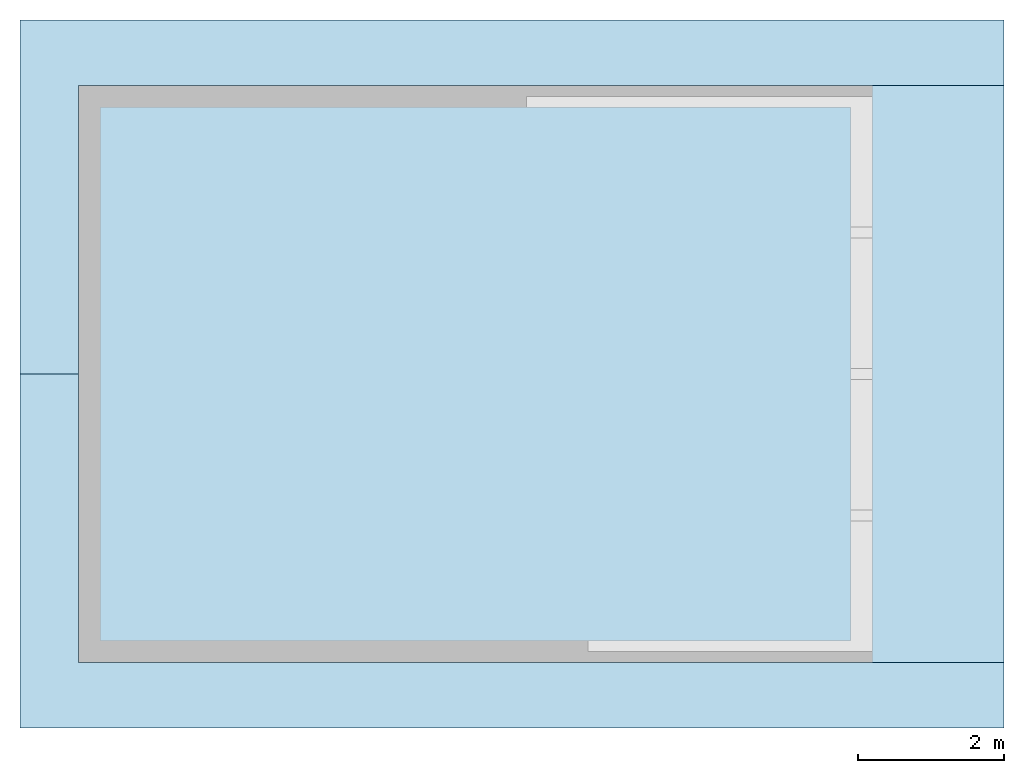
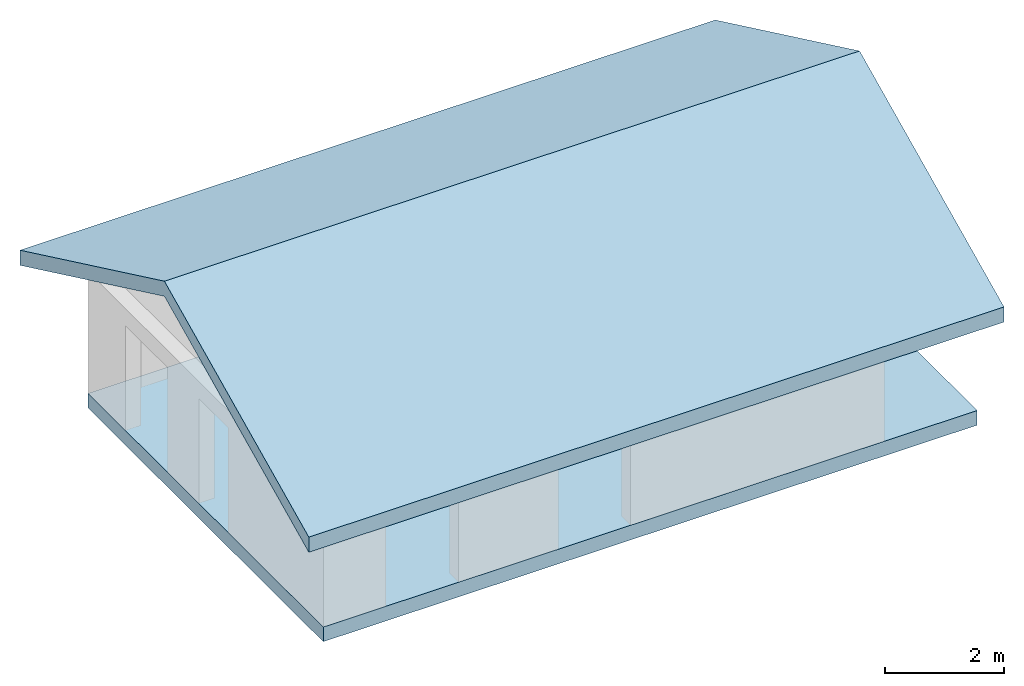
# Not in any storey, part 1 of 2: 2 slabs.
"""IFC4 model written with IfcOpenShell, lengths in metres."""

from ifc_helpers import new_model, entity, si_unit, converted_unit, frame, frame_2d, origin_with_axes, place, context, subcontext, project, polygons, material, element, save


model = new_model("IFC4")

# Units and contexts
model_context = context("Model", 3, precision=1e-05, world=origin_with_axes())
plan_context = context("Plan", 2, precision=1e-05, world=frame_2d((0.0, 0.0, 0.0), x_axis=(1.0, 0.0, 0.0)))
body_context = subcontext(model_context, "Body", "Model", "MODEL_VIEW")
ifc_project = project(units=[converted_unit("PLANEANGLEUNIT", "degree", entity("IfcReal", 0.0174532925199433), si_unit("PLANEANGLEUNIT", "RADIAN"), dimensions=[0, 0, 0, 0, 0, 0, 0]), si_unit("AREAUNIT", "SQUARE_METRE"), si_unit("VOLUMEUNIT", "CUBIC_METRE"), si_unit("LENGTHUNIT", "METRE")], contexts=[model_context, plan_context])

# Slabs
ifc_material = material(Name="concrete")
slab_1_placement = place(None, origin_with_axes())
element("IfcSlab", 1, at=slab_1_placement, material=ifc_material, PredefinedType="BASESLAB", context=body_context, shape_type="Tessellation", body=[
    polygons([(5.6100001335144, -0.400000005960464, 0.300000011920929), (4.21000003814697, -0.100000001490116, 0.300000011920929), (4.21000003814697, -0.400000005960464, 0.300000011920929), (5.6100001335144, -0.100000001490116, 0.300000011920929), (10.5299997329712, 7.5, 0.0), (10.5299997329712, -0.400000005960464, 0.300000011920929), (10.5299997329712, -0.400000005960464, 0.0), (10.5299997329712, 3.25999999046326, 0.300000011920929), (10.5299997329712, 7.19999980926514, 0.300000011920929), (10.5299997329712, 7.5, 0.300000011920929), (-0.349999994039536, 7.5, 0.300000011920929), (-0.349999994039536, 7.5, 0.0), (5.69000005722046, 7.5, 0.300000011920929), (10.2299995422363, 7.5, 0.300000011920929), (-0.349999994039536, 2.79999995231628, 0.300000011920929), (-0.349999994039536, -0.400000005960464, 0.0), (-0.349999994039536, -0.400000005960464, 0.300000011920929), (-0.349999994039536, 3.88000011444092, 0.300000011920929), (-0.349999994039536, 4.82895946502686, 0.300000011920929), (-0.349999994039536, 6.52895927429199, 0.300000011920929), (2.26999998092651, -0.400000005960464, 0.300000011920929), (0.870000004768372, -0.400000005960464, 0.300000011920929), (12.3299999237061, 7.5, 0.0), (12.3299999237061, -0.400000005960464, 0.300000011920929), (12.3299999237061, -0.400000005960464, 0.0), (12.3299999237061, 7.5, 0.300000011920929), (0.870000004768372, -0.100000001490116, 0.300000011920929), (2.26999998092651, -0.100000001490116, 0.300000011920929), (-0.0500000007450581, 4.82895946502686, 0.300000011920929), (-0.0500000007450581, 6.52895927429199, 0.300000011920929), (-0.0500000007450581, 2.79999995231628, 0.300000011920929), (-0.0500000007450581, 3.87984991073608, 0.300000011920929), (-0.0500000007450581, 3.88000011444092, 0.300000011920929), (10.2299995422363, 7.19999980926514, 0.300000011920929), (5.69000005722046, 7.19999980926514, 0.300000011920929), (3.25, 3.87984991073608, 0.300000011920929), (-0.0500000007450581, 7.19999980926514, 0.300000011920929), (3.25, 7.19999980926514, 0.300000011920929), (-0.0500000007450581, 2.70015001296997, 0.300000011920929), (-0.0500000007450581, -0.100000001490116, 0.300000011920929), (3.19000005722046, 2.70015001296997, 0.300000011920929), (3.19000005722046, -0.100000001490116, 0.300000011920929), (3.28999996185303, 2.70015001296997, 0.300000011920929), (3.28999996185303, -0.100000001490116, 0.300000011920929), (6.53000020980835, 2.70015001296997, 0.300000011920929), (6.53000020980835, -0.100000001490116, 0.300000011920929), (10.2299995422363, 3.25999999046326, 0.300000011920929), (3.34999990463257, 5.30000019073486, 0.300000011920929), (3.34984993934631, 7.19999980926514, 0.300000011920929), (3.34984993934631, 5.30000019073486, 0.300000011920929), (3.34999990463257, 7.19999980926514, 0.300000011920929), (5.69000005722046, 5.30000019073486, 0.300000011920929), (4.78999996185303, 3.7801501750946, 0.300000011920929), (3.34999990463257, 3.87984991073608, 0.300000011920929), (3.34999990463257, 3.7801501750946, 0.300000011920929), (3.34999990463257, 5.19999980926514, 0.300000011920929), (4.78999996185303, 4.32000017166138, 0.300000011920929), (5.69000005722046, 5.19999980926514, 0.300000011920929), (5.69000005722046, 4.32000017166138, 0.300000011920929), (10.2299995422363, -0.100000001490116, 0.300000011920929)], [[[1, 2, 3]], [[2, 1, 4]], [[21, 27, 22]], [[27, 21, 28]], [[29, 20, 19]], [[20, 29, 30]], [[31, 18, 15]], [[18, 31, 32]], [[33, 18, 32]], [[34, 13, 35]], [[13, 34, 14]], [[8, 34, 47]], [[34, 8, 9]]]),
    polygons([(5.6100001335144, -0.400000005960464, 0.300000011920929), (4.21000003814697, -0.100000001490116, 0.300000011920929), (4.21000003814697, -0.400000005960464, 0.300000011920929), (5.6100001335144, -0.100000001490116, 0.300000011920929), (10.5299997329712, 7.5, 0.0), (10.5299997329712, -0.400000005960464, 0.300000011920929), (10.5299997329712, -0.400000005960464, 0.0), (10.5299997329712, 3.25999999046326, 0.300000011920929), (10.5299997329712, 7.19999980926514, 0.300000011920929), (10.5299997329712, 7.5, 0.300000011920929), (-0.349999994039536, 7.5, 0.300000011920929), (-0.349999994039536, 7.5, 0.0), (5.69000005722046, 7.5, 0.300000011920929), (10.2299995422363, 7.5, 0.300000011920929), (-0.349999994039536, 2.79999995231628, 0.300000011920929), (-0.349999994039536, -0.400000005960464, 0.0), (-0.349999994039536, -0.400000005960464, 0.300000011920929), (-0.349999994039536, 3.88000011444092, 0.300000011920929), (-0.349999994039536, 4.82895946502686, 0.300000011920929), (-0.349999994039536, 6.52895927429199, 0.300000011920929), (2.26999998092651, -0.400000005960464, 0.300000011920929), (0.870000004768372, -0.400000005960464, 0.300000011920929), (12.3299999237061, 7.5, 0.0), (12.3299999237061, -0.400000005960464, 0.300000011920929), (12.3299999237061, -0.400000005960464, 0.0), (12.3299999237061, 7.5, 0.300000011920929), (0.870000004768372, -0.100000001490116, 0.300000011920929), (2.26999998092651, -0.100000001490116, 0.300000011920929), (-0.0500000007450581, 4.82895946502686, 0.300000011920929), (-0.0500000007450581, 6.52895927429199, 0.300000011920929), (-0.0500000007450581, 2.79999995231628, 0.300000011920929), (-0.0500000007450581, 3.87984991073608, 0.300000011920929), (-0.0500000007450581, 3.88000011444092, 0.300000011920929), (10.2299995422363, 7.19999980926514, 0.300000011920929), (5.69000005722046, 7.19999980926514, 0.300000011920929), (3.25, 3.87984991073608, 0.300000011920929), (-0.0500000007450581, 7.19999980926514, 0.300000011920929), (3.25, 7.19999980926514, 0.300000011920929), (-0.0500000007450581, 2.70015001296997, 0.300000011920929), (-0.0500000007450581, -0.100000001490116, 0.300000011920929), (3.19000005722046, 2.70015001296997, 0.300000011920929), (3.19000005722046, -0.100000001490116, 0.300000011920929), (3.28999996185303, 2.70015001296997, 0.300000011920929), (3.28999996185303, -0.100000001490116, 0.300000011920929), (6.53000020980835, 2.70015001296997, 0.300000011920929), (6.53000020980835, -0.100000001490116, 0.300000011920929), (10.2299995422363, 3.25999999046326, 0.300000011920929), (3.34999990463257, 5.30000019073486, 0.300000011920929), (3.34984993934631, 7.19999980926514, 0.300000011920929), (3.34984993934631, 5.30000019073486, 0.300000011920929), (3.34999990463257, 7.19999980926514, 0.300000011920929), (5.69000005722046, 5.30000019073486, 0.300000011920929), (4.78999996185303, 3.7801501750946, 0.300000011920929), (3.34999990463257, 3.87984991073608, 0.300000011920929), (3.34999990463257, 3.7801501750946, 0.300000011920929), (3.34999990463257, 5.19999980926514, 0.300000011920929), (4.78999996185303, 4.32000017166138, 0.300000011920929), (5.69000005722046, 5.19999980926514, 0.300000011920929), (5.69000005722046, 4.32000017166138, 0.300000011920929), (10.2299995422363, -0.100000001490116, 0.300000011920929)], [[[5, 6, 7]], [[6, 5, 8]], [[8, 5, 9]], [[9, 5, 10]], [[5, 16, 12]], [[16, 5, 7]], [[23, 7, 5]], [[7, 23, 25]], [[33, 19, 18]], [[19, 33, 29]], [[9, 14, 34]], [[14, 9, 10]], [[3, 28, 21]], [[28, 3, 42]], [[42, 3, 44]], [[44, 3, 2]], [[30, 11, 20]], [[11, 30, 37]], [[11, 37, 13]], [[13, 37, 38]], [[13, 38, 49]], [[13, 49, 51]], [[13, 51, 35]], [[44, 41, 42]], [[41, 44, 43]], [[15, 39, 31]], [[39, 15, 40]], [[17, 40, 15]], [[40, 17, 22]], [[40, 22, 27]], [[1, 6, 4]], [[4, 6, 46]], [[46, 6, 60]], [[60, 6, 47]], [[47, 6, 8]], [[54, 38, 36]], [[38, 54, 50]], [[50, 54, 48]], [[48, 54, 56]], [[48, 56, 58]], [[48, 58, 52]], [[49, 38, 50]]]),
    polygons([(5.6100001335144, -0.400000005960464, 0.300000011920929), (4.21000003814697, -0.100000001490116, 0.300000011920929), (4.21000003814697, -0.400000005960464, 0.300000011920929), (5.6100001335144, -0.100000001490116, 0.300000011920929), (10.5299997329712, 7.5, 0.0), (10.5299997329712, -0.400000005960464, 0.300000011920929), (10.5299997329712, -0.400000005960464, 0.0), (10.5299997329712, 3.25999999046326, 0.300000011920929), (10.5299997329712, 7.19999980926514, 0.300000011920929), (10.5299997329712, 7.5, 0.300000011920929), (-0.349999994039536, 7.5, 0.300000011920929), (-0.349999994039536, 7.5, 0.0), (5.69000005722046, 7.5, 0.300000011920929), (10.2299995422363, 7.5, 0.300000011920929), (-0.349999994039536, 2.79999995231628, 0.300000011920929), (-0.349999994039536, -0.400000005960464, 0.0), (-0.349999994039536, -0.400000005960464, 0.300000011920929), (-0.349999994039536, 3.88000011444092, 0.300000011920929), (-0.349999994039536, 4.82895946502686, 0.300000011920929), (-0.349999994039536, 6.52895927429199, 0.300000011920929), (2.26999998092651, -0.400000005960464, 0.300000011920929), (0.870000004768372, -0.400000005960464, 0.300000011920929), (12.3299999237061, 7.5, 0.0), (12.3299999237061, -0.400000005960464, 0.300000011920929), (12.3299999237061, -0.400000005960464, 0.0), (12.3299999237061, 7.5, 0.300000011920929), (0.870000004768372, -0.100000001490116, 0.300000011920929), (2.26999998092651, -0.100000001490116, 0.300000011920929), (-0.0500000007450581, 4.82895946502686, 0.300000011920929), (-0.0500000007450581, 6.52895927429199, 0.300000011920929), (-0.0500000007450581, 2.79999995231628, 0.300000011920929), (-0.0500000007450581, 3.87984991073608, 0.300000011920929), (-0.0500000007450581, 3.88000011444092, 0.300000011920929), (10.2299995422363, 7.19999980926514, 0.300000011920929), (5.69000005722046, 7.19999980926514, 0.300000011920929), (3.25, 3.87984991073608, 0.300000011920929), (-0.0500000007450581, 7.19999980926514, 0.300000011920929), (3.25, 7.19999980926514, 0.300000011920929), (-0.0500000007450581, 2.70015001296997, 0.300000011920929), (-0.0500000007450581, -0.100000001490116, 0.300000011920929), (3.19000005722046, 2.70015001296997, 0.300000011920929), (3.19000005722046, -0.100000001490116, 0.300000011920929), (3.28999996185303, 2.70015001296997, 0.300000011920929), (3.28999996185303, -0.100000001490116, 0.300000011920929), (6.53000020980835, 2.70015001296997, 0.300000011920929), (6.53000020980835, -0.100000001490116, 0.300000011920929), (10.2299995422363, 3.25999999046326, 0.300000011920929), (3.34999990463257, 5.30000019073486, 0.300000011920929), (3.34984993934631, 7.19999980926514, 0.300000011920929), (3.34984993934631, 5.30000019073486, 0.300000011920929), (3.34999990463257, 7.19999980926514, 0.300000011920929), (5.69000005722046, 5.30000019073486, 0.300000011920929), (4.78999996185303, 3.7801501750946, 0.300000011920929), (3.34999990463257, 3.87984991073608, 0.300000011920929), (3.34999990463257, 3.7801501750946, 0.300000011920929), (3.34999990463257, 5.19999980926514, 0.300000011920929), (4.78999996185303, 4.32000017166138, 0.300000011920929), (5.69000005722046, 5.19999980926514, 0.300000011920929), (5.69000005722046, 4.32000017166138, 0.300000011920929), (10.2299995422363, -0.100000001490116, 0.300000011920929)], [[[11, 5, 12]], [[5, 11, 10]], [[10, 11, 13]], [[10, 13, 14]], [[15, 16, 17]], [[16, 15, 12]], [[12, 15, 18]], [[12, 18, 19]], [[12, 19, 20]], [[12, 20, 11]], [[6, 16, 7]], [[16, 6, 17]], [[1, 17, 6]], [[17, 1, 3]], [[17, 3, 21]], [[17, 21, 22]], [[23, 24, 25]], [[24, 23, 26]], [[10, 23, 5]], [[23, 10, 26]], [[24, 8, 6]], [[8, 24, 9]], [[9, 24, 10]], [[10, 24, 26]], [[24, 7, 25]], [[7, 24, 6]]]),
    polygons([(5.6100001335144, -0.400000005960464, 0.300000011920929), (4.21000003814697, -0.100000001490116, 0.300000011920929), (4.21000003814697, -0.400000005960464, 0.300000011920929), (5.6100001335144, -0.100000001490116, 0.300000011920929), (10.5299997329712, 7.5, 0.0), (10.5299997329712, -0.400000005960464, 0.300000011920929), (10.5299997329712, -0.400000005960464, 0.0), (10.5299997329712, 3.25999999046326, 0.300000011920929), (10.5299997329712, 7.19999980926514, 0.300000011920929), (10.5299997329712, 7.5, 0.300000011920929), (-0.349999994039536, 7.5, 0.300000011920929), (-0.349999994039536, 7.5, 0.0), (5.69000005722046, 7.5, 0.300000011920929), (10.2299995422363, 7.5, 0.300000011920929), (-0.349999994039536, 2.79999995231628, 0.300000011920929), (-0.349999994039536, -0.400000005960464, 0.0), (-0.349999994039536, -0.400000005960464, 0.300000011920929), (-0.349999994039536, 3.88000011444092, 0.300000011920929), (-0.349999994039536, 4.82895946502686, 0.300000011920929), (-0.349999994039536, 6.52895927429199, 0.300000011920929), (2.26999998092651, -0.400000005960464, 0.300000011920929), (0.870000004768372, -0.400000005960464, 0.300000011920929), (12.3299999237061, 7.5, 0.0), (12.3299999237061, -0.400000005960464, 0.300000011920929), (12.3299999237061, -0.400000005960464, 0.0), (12.3299999237061, 7.5, 0.300000011920929), (0.870000004768372, -0.100000001490116, 0.300000011920929), (2.26999998092651, -0.100000001490116, 0.300000011920929), (-0.0500000007450581, 4.82895946502686, 0.300000011920929), (-0.0500000007450581, 6.52895927429199, 0.300000011920929), (-0.0500000007450581, 2.79999995231628, 0.300000011920929), (-0.0500000007450581, 3.87984991073608, 0.300000011920929), (-0.0500000007450581, 3.88000011444092, 0.300000011920929), (10.2299995422363, 7.19999980926514, 0.300000011920929), (5.69000005722046, 7.19999980926514, 0.300000011920929), (3.25, 3.87984991073608, 0.300000011920929), (-0.0500000007450581, 7.19999980926514, 0.300000011920929), (3.25, 7.19999980926514, 0.300000011920929), (-0.0500000007450581, 2.70015001296997, 0.300000011920929), (-0.0500000007450581, -0.100000001490116, 0.300000011920929), (3.19000005722046, 2.70015001296997, 0.300000011920929), (3.19000005722046, -0.100000001490116, 0.300000011920929), (3.28999996185303, 2.70015001296997, 0.300000011920929), (3.28999996185303, -0.100000001490116, 0.300000011920929), (6.53000020980835, 2.70015001296997, 0.300000011920929), (6.53000020980835, -0.100000001490116, 0.300000011920929), (10.2299995422363, 3.25999999046326, 0.300000011920929), (3.34999990463257, 5.30000019073486, 0.300000011920929), (3.34984993934631, 7.19999980926514, 0.300000011920929), (3.34984993934631, 5.30000019073486, 0.300000011920929), (3.34999990463257, 7.19999980926514, 0.300000011920929), (5.69000005722046, 5.30000019073486, 0.300000011920929), (4.78999996185303, 3.7801501750946, 0.300000011920929), (3.34999990463257, 3.87984991073608, 0.300000011920929), (3.34999990463257, 3.7801501750946, 0.300000011920929), (3.34999990463257, 5.19999980926514, 0.300000011920929), (4.78999996185303, 4.32000017166138, 0.300000011920929), (5.69000005722046, 5.19999980926514, 0.300000011920929), (5.69000005722046, 4.32000017166138, 0.300000011920929), (10.2299995422363, -0.100000001490116, 0.300000011920929)], [[[36, 33, 32]], [[33, 36, 29]], [[29, 36, 30]], [[30, 36, 37]], [[37, 36, 38]], [[27, 39, 40]], [[39, 27, 41]], [[41, 27, 28]], [[41, 28, 42]], [[2, 43, 44]], [[43, 2, 45]], [[45, 2, 4]], [[45, 4, 46]]]),
    polygons([(5.6100001335144, -0.400000005960464, 0.300000011920929), (4.21000003814697, -0.100000001490116, 0.300000011920929), (4.21000003814697, -0.400000005960464, 0.300000011920929), (5.6100001335144, -0.100000001490116, 0.300000011920929), (10.5299997329712, 7.5, 0.0), (10.5299997329712, -0.400000005960464, 0.300000011920929), (10.5299997329712, -0.400000005960464, 0.0), (10.5299997329712, 3.25999999046326, 0.300000011920929), (10.5299997329712, 7.19999980926514, 0.300000011920929), (10.5299997329712, 7.5, 0.300000011920929), (-0.349999994039536, 7.5, 0.300000011920929), (-0.349999994039536, 7.5, 0.0), (5.69000005722046, 7.5, 0.300000011920929), (10.2299995422363, 7.5, 0.300000011920929), (-0.349999994039536, 2.79999995231628, 0.300000011920929), (-0.349999994039536, -0.400000005960464, 0.0), (-0.349999994039536, -0.400000005960464, 0.300000011920929), (-0.349999994039536, 3.88000011444092, 0.300000011920929), (-0.349999994039536, 4.82895946502686, 0.300000011920929), (-0.349999994039536, 6.52895927429199, 0.300000011920929), (2.26999998092651, -0.400000005960464, 0.300000011920929), (0.870000004768372, -0.400000005960464, 0.300000011920929), (12.3299999237061, 7.5, 0.0), (12.3299999237061, -0.400000005960464, 0.300000011920929), (12.3299999237061, -0.400000005960464, 0.0), (12.3299999237061, 7.5, 0.300000011920929), (0.870000004768372, -0.100000001490116, 0.300000011920929), (2.26999998092651, -0.100000001490116, 0.300000011920929), (-0.0500000007450581, 4.82895946502686, 0.300000011920929), (-0.0500000007450581, 6.52895927429199, 0.300000011920929), (-0.0500000007450581, 2.79999995231628, 0.300000011920929), (-0.0500000007450581, 3.87984991073608, 0.300000011920929), (-0.0500000007450581, 3.88000011444092, 0.300000011920929), (10.2299995422363, 7.19999980926514, 0.300000011920929), (5.69000005722046, 7.19999980926514, 0.300000011920929), (3.25, 3.87984991073608, 0.300000011920929), (-0.0500000007450581, 7.19999980926514, 0.300000011920929), (3.25, 7.19999980926514, 0.300000011920929), (-0.0500000007450581, 2.70015001296997, 0.300000011920929), (-0.0500000007450581, -0.100000001490116, 0.300000011920929), (3.19000005722046, 2.70015001296997, 0.300000011920929), (3.19000005722046, -0.100000001490116, 0.300000011920929), (3.28999996185303, 2.70015001296997, 0.300000011920929), (3.28999996185303, -0.100000001490116, 0.300000011920929), (6.53000020980835, 2.70015001296997, 0.300000011920929), (6.53000020980835, -0.100000001490116, 0.300000011920929), (10.2299995422363, 3.25999999046326, 0.300000011920929), (3.34999990463257, 5.30000019073486, 0.300000011920929), (3.34984993934631, 7.19999980926514, 0.300000011920929), (3.34984993934631, 5.30000019073486, 0.300000011920929), (3.34999990463257, 7.19999980926514, 0.300000011920929), (5.69000005722046, 5.30000019073486, 0.300000011920929), (4.78999996185303, 3.7801501750946, 0.300000011920929), (3.34999990463257, 3.87984991073608, 0.300000011920929), (3.34999990463257, 3.7801501750946, 0.300000011920929), (3.34999990463257, 5.19999980926514, 0.300000011920929), (4.78999996185303, 4.32000017166138, 0.300000011920929), (5.69000005722046, 5.19999980926514, 0.300000011920929), (5.69000005722046, 4.32000017166138, 0.300000011920929), (10.2299995422363, -0.100000001490116, 0.300000011920929)], [[[48, 49, 50]], [[49, 48, 51]], [[41, 31, 39]], [[60, 45, 46]], [[45, 55, 43]], [[55, 45, 53]], [[53, 45, 57]], [[57, 45, 59]], [[59, 45, 58]], [[58, 45, 35]], [[35, 45, 34]], [[34, 45, 60]], [[34, 60, 47]], [[35, 52, 58]], [[31, 36, 32]], [[36, 31, 41]], [[36, 41, 43]], [[36, 43, 54]], [[54, 43, 55]]]),
    polygons([(5.6100001335144, -0.400000005960464, 0.300000011920929), (4.21000003814697, -0.100000001490116, 0.300000011920929), (4.21000003814697, -0.400000005960464, 0.300000011920929), (5.6100001335144, -0.100000001490116, 0.300000011920929), (10.5299997329712, 7.5, 0.0), (10.5299997329712, -0.400000005960464, 0.300000011920929), (10.5299997329712, -0.400000005960464, 0.0), (10.5299997329712, 3.25999999046326, 0.300000011920929), (10.5299997329712, 7.19999980926514, 0.300000011920929), (10.5299997329712, 7.5, 0.300000011920929), (-0.349999994039536, 7.5, 0.300000011920929), (-0.349999994039536, 7.5, 0.0), (5.69000005722046, 7.5, 0.300000011920929), (10.2299995422363, 7.5, 0.300000011920929), (-0.349999994039536, 2.79999995231628, 0.300000011920929), (-0.349999994039536, -0.400000005960464, 0.0), (-0.349999994039536, -0.400000005960464, 0.300000011920929), (-0.349999994039536, 3.88000011444092, 0.300000011920929), (-0.349999994039536, 4.82895946502686, 0.300000011920929), (-0.349999994039536, 6.52895927429199, 0.300000011920929), (2.26999998092651, -0.400000005960464, 0.300000011920929), (0.870000004768372, -0.400000005960464, 0.300000011920929), (12.3299999237061, 7.5, 0.0), (12.3299999237061, -0.400000005960464, 0.300000011920929), (12.3299999237061, -0.400000005960464, 0.0), (12.3299999237061, 7.5, 0.300000011920929), (0.870000004768372, -0.100000001490116, 0.300000011920929), (2.26999998092651, -0.100000001490116, 0.300000011920929), (-0.0500000007450581, 4.82895946502686, 0.300000011920929), (-0.0500000007450581, 6.52895927429199, 0.300000011920929), (-0.0500000007450581, 2.79999995231628, 0.300000011920929), (-0.0500000007450581, 3.87984991073608, 0.300000011920929), (-0.0500000007450581, 3.88000011444092, 0.300000011920929), (10.2299995422363, 7.19999980926514, 0.300000011920929), (5.69000005722046, 7.19999980926514, 0.300000011920929), (3.25, 3.87984991073608, 0.300000011920929), (-0.0500000007450581, 7.19999980926514, 0.300000011920929), (3.25, 7.19999980926514, 0.300000011920929), (-0.0500000007450581, 2.70015001296997, 0.300000011920929), (-0.0500000007450581, -0.100000001490116, 0.300000011920929), (3.19000005722046, 2.70015001296997, 0.300000011920929), (3.19000005722046, -0.100000001490116, 0.300000011920929), (3.28999996185303, 2.70015001296997, 0.300000011920929), (3.28999996185303, -0.100000001490116, 0.300000011920929), (6.53000020980835, 2.70015001296997, 0.300000011920929), (6.53000020980835, -0.100000001490116, 0.300000011920929), (10.2299995422363, 3.25999999046326, 0.300000011920929), (3.34999990463257, 5.30000019073486, 0.300000011920929), (3.34984993934631, 7.19999980926514, 0.300000011920929), (3.34984993934631, 5.30000019073486, 0.300000011920929), (3.34999990463257, 7.19999980926514, 0.300000011920929), (5.69000005722046, 5.30000019073486, 0.300000011920929), (4.78999996185303, 3.7801501750946, 0.300000011920929), (3.34999990463257, 3.87984991073608, 0.300000011920929), (3.34999990463257, 3.7801501750946, 0.300000011920929), (3.34999990463257, 5.19999980926514, 0.300000011920929), (4.78999996185303, 4.32000017166138, 0.300000011920929), (5.69000005722046, 5.19999980926514, 0.300000011920929), (5.69000005722046, 4.32000017166138, 0.300000011920929), (10.2299995422363, -0.100000001490116, 0.300000011920929)], [[[52, 51, 48]], [[51, 52, 35]], [[53, 54, 55]], [[54, 53, 56]], [[56, 53, 57]], [[56, 57, 58]], [[58, 57, 59]]]),
])
slab_2_placement = place(None, frame((-1.14999997615814, -1.29999995231628, 2.65933060646057), z_axis=(0.0, 0.0, 1.0), x_axis=(1.0, 0.0, 0.0)))
element("IfcSlab", 2, at=slab_2_placement, PredefinedType="BASESLAB", context=body_context, shape_type="Tessellation", body=[
    polygons([(13.4799995422363, 2.34621201895097e-15, 0.209999993443489), (13.4799995422363, 4.84999990463257, 2.61589884757996), (13.4799995422363, 1.98525634001684e-15, 0.310000002384186), (13.4799995422363, 4.84999990463257, 2.51589870452881), (13.4799995422363, 9.69999980926514, 0.209999993443489), (13.4799995422363, 9.69999980926514, 0.310000002384186), (7.21911410807822e-16, 3.60955705403911e-16, 0.209999993443489), (0.0, 0.0, 0.310000002384186), (0.0, 4.84999990463257, 2.61589884757996), (7.21911410807822e-16, 4.84999990463257, 2.51589870452881), (0.0, 9.69999980926514, 0.310000002384186), (7.21911410807822e-16, 9.69999980926514, 0.209999993443489), (0.0, 9.69999980926514, 4.33146857072605e-15), (13.4799995422363, 9.69999980926514, 0.0), (0.0, 3.24860132216542e-15, 4.33146857072605e-15), (0.0, 4.84999990463257, 2.30589866638184), (13.4799995422363, 5.23385766218226e-15, 0.0), (13.4799995422363, 4.84999990463257, 2.30589866638184), (11.6800003051758, 4.84999990463257, 2.30589866638184), (0.800000011920929, 0.899999976158142, 0.427898734807968), (0.800000011920929, 4.84999990463257, 2.30589866638184), (11.6800003051758, 0.899999976158142, 0.427898734807968), (11.6800003051758, 8.80000019073486, 0.427898734807968), (0.800000011920929, 8.80000019073486, 0.427898734807968)], [[[1, 2, 3]], [[2, 1, 4]], [[2, 4, 5]], [[2, 5, 6]], [[1, 3, 7]], [[7, 3, 8]], [[9, 7, 8]], [[7, 9, 10]], [[10, 9, 11]], [[10, 11, 12]], [[12, 6, 5]], [[6, 12, 11]]]),
    polygons([(13.4799995422363, 2.34621201895097e-15, 0.209999993443489), (13.4799995422363, 4.84999990463257, 2.61589884757996), (13.4799995422363, 1.98525634001684e-15, 0.310000002384186), (13.4799995422363, 4.84999990463257, 2.51589870452881), (13.4799995422363, 9.69999980926514, 0.209999993443489), (13.4799995422363, 9.69999980926514, 0.310000002384186), (7.21911410807822e-16, 3.60955705403911e-16, 0.209999993443489), (0.0, 0.0, 0.310000002384186), (0.0, 4.84999990463257, 2.61589884757996), (7.21911410807822e-16, 4.84999990463257, 2.51589870452881), (0.0, 9.69999980926514, 0.310000002384186), (7.21911410807822e-16, 9.69999980926514, 0.209999993443489), (0.0, 9.69999980926514, 4.33146857072605e-15), (13.4799995422363, 9.69999980926514, 0.0), (0.0, 3.24860132216542e-15, 4.33146857072605e-15), (0.0, 4.84999990463257, 2.30589866638184), (13.4799995422363, 5.23385766218226e-15, 0.0), (13.4799995422363, 4.84999990463257, 2.30589866638184), (11.6800003051758, 4.84999990463257, 2.30589866638184), (0.800000011920929, 0.899999976158142, 0.427898734807968), (0.800000011920929, 4.84999990463257, 2.30589866638184), (11.6800003051758, 0.899999976158142, 0.427898734807968), (11.6800003051758, 8.80000019073486, 0.427898734807968), (0.800000011920929, 8.80000019073486, 0.427898734807968)], [[[13, 5, 14]], [[5, 13, 12]], [[10, 15, 7]], [[15, 10, 16]], [[16, 10, 12]], [[16, 12, 13]], [[1, 17, 4]], [[4, 17, 18]], [[4, 18, 14]], [[4, 14, 5]], [[1, 15, 17]], [[15, 1, 7]], [[13, 24, 16]], [[24, 13, 14]], [[24, 14, 23]], [[23, 14, 19]], [[19, 14, 18]], [[21, 16, 24]], [[18, 22, 19]], [[21, 15, 16]], [[15, 21, 20]], [[15, 20, 17]], [[17, 20, 22]], [[17, 22, 18]]]),
    polygons([(13.4799995422363, 2.34621201895097e-15, 0.209999993443489), (13.4799995422363, 4.84999990463257, 2.61589884757996), (13.4799995422363, 1.98525634001684e-15, 0.310000002384186), (13.4799995422363, 4.84999990463257, 2.51589870452881), (13.4799995422363, 9.69999980926514, 0.209999993443489), (13.4799995422363, 9.69999980926514, 0.310000002384186), (7.21911410807822e-16, 3.60955705403911e-16, 0.209999993443489), (0.0, 0.0, 0.310000002384186), (0.0, 4.84999990463257, 2.61589884757996), (7.21911410807822e-16, 4.84999990463257, 2.51589870452881), (0.0, 9.69999980926514, 0.310000002384186), (7.21911410807822e-16, 9.69999980926514, 0.209999993443489), (0.0, 9.69999980926514, 4.33146857072605e-15), (13.4799995422363, 9.69999980926514, 0.0), (0.0, 3.24860132216542e-15, 4.33146857072605e-15), (0.0, 4.84999990463257, 2.30589866638184), (13.4799995422363, 5.23385766218226e-15, 0.0), (13.4799995422363, 4.84999990463257, 2.30589866638184), (11.6800003051758, 4.84999990463257, 2.30589866638184), (0.800000011920929, 0.899999976158142, 0.427898734807968), (0.800000011920929, 4.84999990463257, 2.30589866638184), (11.6800003051758, 0.899999976158142, 0.427898734807968), (11.6800003051758, 8.80000019073486, 0.427898734807968), (0.800000011920929, 8.80000019073486, 0.427898734807968)], [[[3, 9, 8]], [[9, 3, 2]], [[2, 11, 9]], [[11, 2, 6]]]),
    polygons([(13.4799995422363, 2.34621201895097e-15, 0.209999993443489), (13.4799995422363, 4.84999990463257, 2.61589884757996), (13.4799995422363, 1.98525634001684e-15, 0.310000002384186), (13.4799995422363, 4.84999990463257, 2.51589870452881), (13.4799995422363, 9.69999980926514, 0.209999993443489), (13.4799995422363, 9.69999980926514, 0.310000002384186), (7.21911410807822e-16, 3.60955705403911e-16, 0.209999993443489), (0.0, 0.0, 0.310000002384186), (0.0, 4.84999990463257, 2.61589884757996), (7.21911410807822e-16, 4.84999990463257, 2.51589870452881), (0.0, 9.69999980926514, 0.310000002384186), (7.21911410807822e-16, 9.69999980926514, 0.209999993443489), (0.0, 9.69999980926514, 4.33146857072605e-15), (13.4799995422363, 9.69999980926514, 0.0), (0.0, 3.24860132216542e-15, 4.33146857072605e-15), (0.0, 4.84999990463257, 2.30589866638184), (13.4799995422363, 5.23385766218226e-15, 0.0), (13.4799995422363, 4.84999990463257, 2.30589866638184), (11.6800003051758, 4.84999990463257, 2.30589866638184), (0.800000011920929, 0.899999976158142, 0.427898734807968), (0.800000011920929, 4.84999990463257, 2.30589866638184), (11.6800003051758, 0.899999976158142, 0.427898734807968), (11.6800003051758, 8.80000019073486, 0.427898734807968), (0.800000011920929, 8.80000019073486, 0.427898734807968)], [[[19, 20, 21]], [[20, 19, 22]], [[23, 21, 24]], [[21, 23, 19]]]),
])

save(model, "model.ifc")
